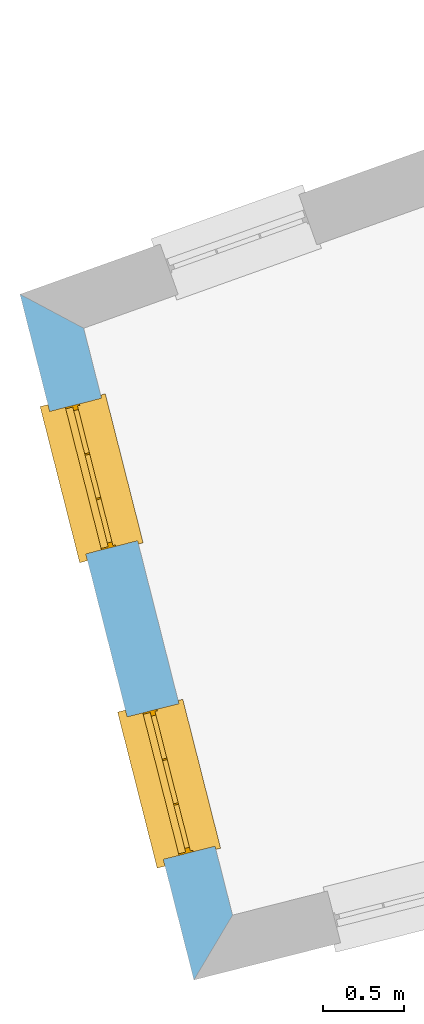
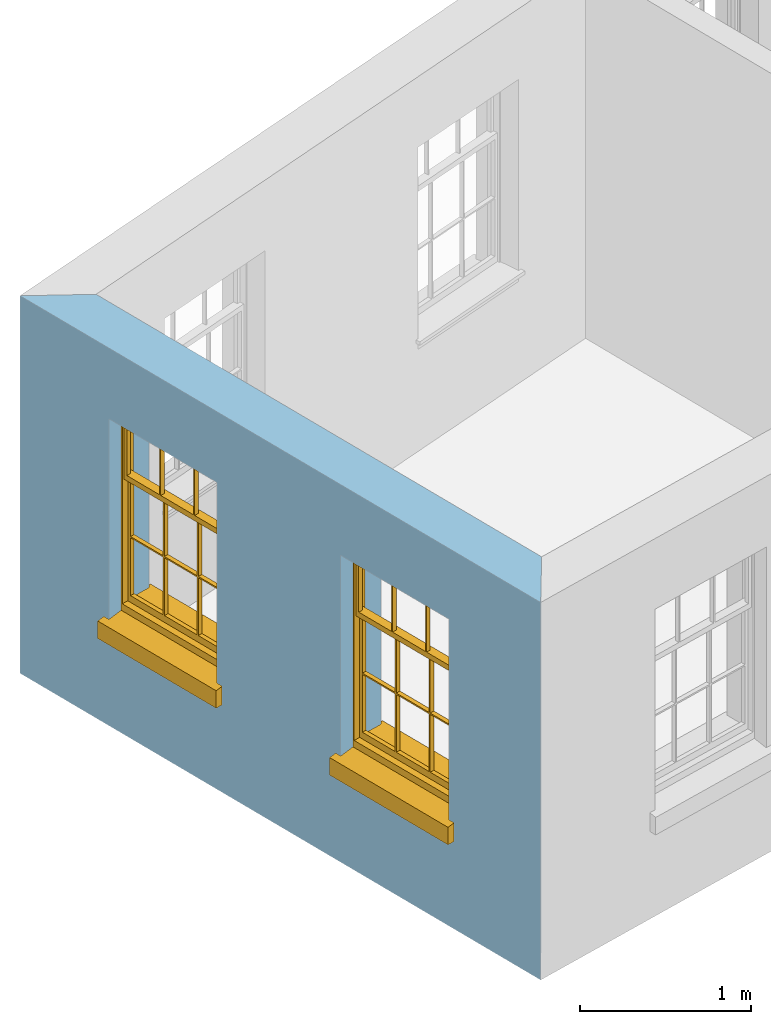
# One storey, part 2 of 10: 2 windows, 2 openings, plus 1 element that does not belong to this part.
"""IFC2X3 building model written with IfcOpenShell, lengths in metres."""

from ifc_helpers import new_model, si_unit, frame, origin, place, context, subcontext, project, spatial, polyline, outline, extrude, faceted_brep, material, layer, layer_set, layer_usage, element, fill, save


model = new_model("IFC2X3")

# Units and contexts
model_context = context("Model", 3, world=origin())
body_context = subcontext(model_context, "Body", "Model", "MODEL_VIEW")
ifc_project = project(units=[si_unit("PLANEANGLEUNIT", "RADIAN"), si_unit("MASSUNIT", "GRAM", prefix="KILO"), si_unit("FORCEUNIT", "NEWTON", prefix="KILO"), si_unit("LENGTHUNIT", "METRE")], contexts=[model_context])

# Site, building, storey
site_placement = place(None, origin())
site = spatial("IfcSite", under=ifc_project, at=site_placement, CompositionType="ELEMENT")
building_placement = place(None, origin())
building = spatial("IfcBuilding", under=site, at=building_placement, Name="Building plot-13", CompositionType="ELEMENT")
storey_placement = place(None, frame((0.0, 0.0, 9.55)))
storey = spatial("IfcBuildingStorey", under=building, at=storey_placement, Name="Floor 2", CompositionType="ELEMENT", Elevation=9.55)

# Wall, openings, windows
ifc_material = material(Name="Masonry")
ifc_layer = layer(ifc_material, 0.33, ventilated=False)
ifc_layer_set = layer_set([ifc_layer], Name="My Wall")
ifc_layer_usage = layer_usage(ifc_layer_set, "AXIS2", "NEGATIVE", 0.08)
wall_placement = place(storey_placement, origin())
wall = element("IfcWallStandardCase", 1, at=wall_placement, inside=storey, material=ifc_layer_usage, Name="exterior", context=body_context, shape_type="SweptSolid", body=[
    extrude(outline(polyline([(65.9065629771408, 47.5401792508866), (65.5129266056267, 47.7498882014907), (66.5879619422004, 43.5112429767636), (66.8267058597151, 43.9122434030099), (65.9065629771408, 47.5401792508866)])), origin(), (0.0, 0.0, 1.0), 2.7),
])
opening_1_placement = place(storey_placement, frame((0.0, 0.0, 0.75)))
opening_1 = element("IfcOpeningElement", 2, at=opening_1_placement, cuts=wall, Name="Opening", ObjectType="Opening", context=body_context, shape_type="SweptSolid", body=[
    extrude(outline(polyline([(65.6963730633974, 47.0265962074796), (65.920090370891, 46.1445244607788), (66.2399625427715, 46.2256527151446), (66.0162452352779, 47.1077244618454), (65.6963730633974, 47.0265962074796)])), origin(), (0.0, 0.0, 1.0), 1.445),
])
opening_2_placement = place(storey_placement, frame((0.0, 0.0, 0.75)))
opening_2 = element("IfcOpeningElement", 3, at=opening_2_placement, cuts=wall, Name="Opening", ObjectType="Opening", context=body_context, shape_type="SweptSolid", body=[
    extrude(outline(polyline([(66.1752193475935, 45.1386029045291), (66.3989366550872, 44.2565311578283), (66.7188088269677, 44.3376594121941), (66.495091519474, 45.2197311588949), (66.1752193475935, 45.1386029045291)])), origin(), (0.0, 0.0, 1.0), 1.445),
])
window_1_placement = place(storey_placement, frame((65.9387004663372, 47.0880570062415, 0.75), z_axis=(0.0, 0.0, 1.0), x_axis=(0.223717307493615, -0.882071746700802, 0.0)))
window_1 = element("IfcWindow", 4, at=window_1_placement, inside=storey, Name="bedroom outside window", OverallHeight=1.445, OverallWidth=0.91, context=body_context, shape_type="Brep", held_by="IfcProductRepresentation", body=[
    faceted_brep([(0.876875, -0.105, 0.999097), (0.876875, -0.105, 1.411875), (0.9, -0.105, 1.435), (0.033125, -0.105, 1.411875), (0.033125, -0.105, 0.999097), (0.01, -0.105, 1.435), (0.033125, -0.135, 1.411875), (0.01, -0.135, 1.435), (0.033125, -0.135, 0.999097), (0.876875, -0.135, 1.411875), (0.876875, -0.135, 0.999097), (0.9, -0.135, 1.435), (0.033125, -0.105, 0.960972), (0.01, -0.105, 0.960972), (0.033125, -0.105, 0.548195), (0.876875, -0.105, 0.960972), (0.876875, -0.105, 0.548195), (0.9, -0.105, 0.960972), (0.876875, -0.105, 0.538195), (0.876875, -0.105, 0.125417), (0.9, -0.105, 0.077167), (0.033125, -0.105, 0.125417), (0.033125, -0.105, 0.538195), (0.01, -0.105, 0.077167), (0.9, -0.135, 0.960972), (0.01, -0.135, 0.960972), (-0.0425, -0.25, 0.01), (-0.0425, -0.3, 0.001667), (0.0, -0.25, 0.01), (0.9525, -0.25, 0.01), (0.91, -0.25, 0.01), (0.9525, -0.3, 0.001667), (-0.02, 0.08, 0.077167), (0.0, 0.08, 0.077167), (-0.02, 0.11, 0.077167), (0.0, -0.06, 0.077167), (0.01, -0.06, 0.077167), (0.91, -0.06, 0.077167), (0.91, 0.08, 0.077167), (0.9, -0.06, 0.077167), (0.93, 0.08, 0.077167), (0.93, 0.11, 0.077167), (0.01, -0.105, 0.999097), (0.01, -0.075, 0.999097), (0.9, -0.105, 0.999097), (0.9, -0.075, 0.999097), (0.876875, -0.075, 0.125417), (0.876875, -0.075, 0.538195), (0.9, -0.075, 0.077167), (0.876875, -0.075, 0.548195), (0.876875, -0.075, 0.960972), (0.033125, -0.075, 0.125417), (0.01, -0.075, 0.077167), (0.033125, -0.075, 0.538195), (0.033125, -0.075, 0.960972), (0.033125, -0.075, 0.548195), (-0.02, 0.08, 0.052167), (-0.02, 0.11, 0.052167), (0.93, 0.11, 0.052167), (0.93, 0.08, 0.052167), (0.91, 0.08, 0.052167), (0.0, 0.08, 0.052167), (0.91, -0.15, 0.026667), (0.0, -0.15, 0.026667), (-0.0425, -0.3, -0.123333), (0.9525, -0.3, -0.123333), (-0.0425, -0.25, -0.123333), (0.9525, -0.25, -0.123333), (0.01, -0.06, 1.435), (0.9, -0.06, 1.435), (0.0, -0.06, 1.445), (0.91, -0.06, 1.445), (0.01, -0.15, 0.077167), (0.9, -0.15, 0.077167), (0.592292, -0.105, 0.125417), (0.592292, -0.075, 0.125417), (0.317708, -0.075, 0.125417), (0.317708, -0.105, 0.125417), (0.592292, -0.105, 0.548195), (0.317708, -0.105, 0.548195), (0.317708, -0.105, 0.538195), (0.592292, -0.105, 0.538195), (0.592292, -0.075, 0.548195), (0.317708, -0.075, 0.548195), (0.602292, -0.075, 0.548195), (0.602292, -0.105, 0.548195), (0.317708, -0.075, 0.538195), (0.307708, -0.075, 0.125417), (0.307708, -0.075, 0.538195), (0.602292, -0.075, 0.538195), (0.602292, -0.075, 0.125417), (0.592292, -0.075, 0.538195), (0.307708, -0.075, 0.548195), (0.317708, -0.075, 0.960972), (0.307708, -0.075, 0.960972), (0.602292, -0.075, 0.960972), (0.592292, -0.075, 0.960972), (0.307708, -0.105, 0.538195), (0.307708, -0.105, 0.125417), (0.307708, -0.105, 0.548195), (0.307708, -0.105, 0.960972), (0.592292, -0.105, 0.960972), (0.317708, -0.105, 0.960972), (0.602292, -0.105, 0.960972), (0.602292, -0.105, 0.538195), (0.602292, -0.105, 0.125417), (0.317708, -0.135, 1.411875), (0.307708, -0.135, 1.411875), (0.307708, -0.135, 0.999097), (0.317708, -0.135, 0.999097), (0.602292, -0.135, 1.411875), (0.592292, -0.135, 1.411875), (0.592292, -0.135, 0.999097), (0.602292, -0.135, 0.999097), (0.317708, -0.105, 0.999097), (0.307708, -0.105, 0.999097), (0.307708, -0.105, 1.411875), (0.317708, -0.105, 1.411875), (0.602292, -0.105, 0.999097), (0.592292, -0.105, 0.999097), (0.592292, -0.105, 1.411875), (0.602292, -0.105, 1.411875), (0.91, -0.15, 1.445), (0.9, -0.15, 1.435), (0.01, -0.15, 1.435), (0.0, -0.15, 1.445), (0.91, -0.25, 0.0), (0.0, -0.25, 0.0), (0.91, 0.08, 0.0), (0.0, 0.08, 0.0)], [[[0, 1, 2]], [[3, 4, 5]], [[6, 7, 8]], [[9, 10, 11]], [[12, 13, 14]], [[15, 16, 17]], [[18, 19, 20]], [[21, 22, 23]], [[24, 15, 17]], [[13, 12, 25]], [[26, 27, 28]], [[29, 30, 31]], [[32, 33, 34]], [[35, 36, 33]], [[37, 38, 39]], [[40, 41, 38]], [[42, 4, 43]], [[44, 45, 0]], [[46, 47, 48]], [[49, 50, 45]], [[51, 52, 53]], [[54, 55, 43]], [[38, 33, 36, 39]], [[41, 34, 33, 38]], [[56, 32, 34, 57]], [[57, 34, 41, 58]], [[58, 41, 40, 59]], [[57, 58, 60, 61]], [[52, 48, 39, 36]], [[62, 63, 28, 30]], [[27, 31, 30, 28]], [[27, 64, 65, 31]], [[66, 67, 65, 64]], [[2, 5, 68, 69]], [[68, 70, 71, 69]], [[20, 23, 72, 73]], [[73, 72, 63, 62]], [[74, 75, 76, 77]], [[78, 79, 80, 81]], [[78, 82, 83, 79]], [[16, 49, 84, 85]], [[86, 76, 87, 88]], [[89, 90, 75, 91]], [[92, 88, 53, 55]], [[82, 91, 86, 83]], [[93, 83, 92, 94]], [[95, 84, 82, 96]], [[89, 84, 49, 47]], [[97, 88, 87, 98]], [[22, 53, 88, 97]], [[81, 91, 75, 74]], [[80, 86, 91, 81]], [[77, 76, 86, 80]], [[99, 92, 55, 14]], [[100, 94, 92, 99]], [[101, 96, 82, 78]], [[79, 83, 93, 102]], [[85, 84, 95, 103]], [[104, 89, 47, 18]], [[105, 90, 89, 104]], [[104, 18, 16, 85]], [[80, 97, 98, 77]], [[104, 81, 74, 105]], [[103, 101, 78, 85]], [[99, 14, 22, 97]], [[102, 100, 99, 79]], [[106, 107, 108, 109]], [[110, 111, 112, 113]], [[114, 115, 116, 117]], [[118, 119, 120, 121]], [[107, 116, 115, 108]], [[111, 120, 119, 112]], [[109, 114, 117, 106]], [[113, 118, 121, 110]], [[85, 78, 81, 104]], [[84, 89, 91, 82]], [[83, 86, 88, 92]], [[79, 99, 97, 80]], [[109, 112, 119, 114]], [[102, 93, 96, 101]], [[106, 117, 120, 111]], [[98, 87, 51, 21]], [[6, 3, 116, 107]], [[110, 121, 1, 9]], [[19, 46, 90, 105]], [[26, 66, 64, 27]], [[29, 31, 65, 67]], [[25, 24, 112, 109]], [[11, 7, 106, 111]], [[75, 48, 52, 76]], [[43, 45, 96, 93]], [[45, 43, 114, 119]], [[5, 2, 120, 117]], [[24, 25, 102, 101]], [[42, 5, 4]], [[2, 44, 0]], [[49, 45, 48, 47]], [[52, 43, 55, 53]], [[14, 13, 23, 22]], [[20, 17, 16, 18]], [[24, 11, 10]], [[25, 8, 7]], [[8, 4, 3, 6]], [[9, 1, 0, 10]], [[15, 50, 49, 16]], [[18, 47, 46, 19]], [[21, 51, 53, 22]], [[14, 55, 54, 12]], [[44, 2, 69, 45]], [[68, 5, 42, 43]], [[36, 35, 70, 68]], [[39, 69, 71, 37]], [[62, 122, 123, 73]], [[63, 72, 124, 125]], [[8, 108, 115, 4]], [[113, 10, 0, 118]], [[94, 100, 12, 54]], [[17, 20, 73, 24]], [[72, 23, 13, 25]], [[52, 36, 68, 43]], [[69, 39, 48, 45]], [[11, 24, 73, 123]], [[7, 124, 72, 25]], [[23, 77, 98]], [[98, 21, 23]], [[105, 74, 20]], [[20, 19, 105]], [[20, 74, 77, 23]], [[113, 112, 24]], [[24, 10, 113]], [[25, 109, 108]], [[108, 8, 25]], [[110, 9, 11]], [[11, 111, 110]], [[7, 6, 107]], [[107, 106, 7]], [[5, 117, 116]], [[116, 3, 5]], [[121, 120, 2]], [[2, 1, 121]], [[11, 123, 124, 7]], [[122, 125, 124, 123]], [[43, 93, 94]], [[94, 54, 43]], [[96, 45, 95]], [[50, 95, 45]], [[15, 103, 95, 50]], [[48, 75, 90]], [[90, 46, 48]], [[87, 76, 52]], [[52, 51, 87]], [[103, 15, 24]], [[24, 101, 103]], [[100, 102, 25]], [[25, 12, 100]], [[115, 114, 43]], [[43, 4, 115]], [[118, 0, 45]], [[45, 119, 118]], [[71, 70, 125, 122]], [[70, 35, 63, 125]], [[122, 62, 37, 71]], [[126, 67, 66, 127]], [[60, 58, 59]], [[38, 60, 59, 40]], [[61, 56, 57]], [[32, 56, 61, 33]], [[61, 60, 128, 129]], [[62, 60, 38, 37]], [[126, 128, 60, 62]], [[33, 61, 63, 35]], [[61, 129, 127, 63]], [[128, 126, 127, 129]], [[28, 127, 66, 26]], [[63, 127, 28]], [[29, 67, 126, 30]], [[30, 126, 62]]]),
])
fill(opening_1, window_1)
window_2_placement = place(storey_placement, frame((66.4175467505333, 45.2000637032911, 0.75), z_axis=(0.0, 0.0, 1.0), x_axis=(0.223717307493615, -0.882071746700802, 0.0)))
window_2 = element("IfcWindow", 5, at=window_2_placement, inside=storey, Name="bedroom outside window", OverallHeight=1.445, OverallWidth=0.91, context=body_context, shape_type="Brep", held_by="IfcProductRepresentation", body=[
    faceted_brep([(0.876875, -0.105, 0.999097), (0.876875, -0.105, 1.411875), (0.9, -0.105, 1.435), (0.033125, -0.105, 1.411875), (0.033125, -0.105, 0.999097), (0.01, -0.105, 1.435), (0.033125, -0.135, 1.411875), (0.01, -0.135, 1.435), (0.033125, -0.135, 0.999097), (0.876875, -0.135, 1.411875), (0.876875, -0.135, 0.999097), (0.9, -0.135, 1.435), (0.033125, -0.105, 0.960972), (0.01, -0.105, 0.960972), (0.033125, -0.105, 0.548195), (0.876875, -0.105, 0.960972), (0.876875, -0.105, 0.548195), (0.9, -0.105, 0.960972), (0.876875, -0.105, 0.538195), (0.876875, -0.105, 0.125417), (0.9, -0.105, 0.077167), (0.033125, -0.105, 0.125417), (0.033125, -0.105, 0.538195), (0.01, -0.105, 0.077167), (0.9, -0.135, 0.960972), (0.01, -0.135, 0.960972), (-0.0425, -0.25, 0.01), (-0.0425, -0.3, 0.001667), (0.0, -0.25, 0.01), (0.9525, -0.25, 0.01), (0.91, -0.25, 0.01), (0.9525, -0.3, 0.001667), (-0.02, 0.08, 0.077167), (0.0, 0.08, 0.077167), (-0.02, 0.11, 0.077167), (0.0, -0.06, 0.077167), (0.01, -0.06, 0.077167), (0.91, -0.06, 0.077167), (0.91, 0.08, 0.077167), (0.9, -0.06, 0.077167), (0.93, 0.08, 0.077167), (0.93, 0.11, 0.077167), (0.01, -0.105, 0.999097), (0.01, -0.075, 0.999097), (0.9, -0.105, 0.999097), (0.9, -0.075, 0.999097), (0.876875, -0.075, 0.125417), (0.876875, -0.075, 0.538195), (0.9, -0.075, 0.077167), (0.876875, -0.075, 0.548195), (0.876875, -0.075, 0.960972), (0.033125, -0.075, 0.125417), (0.01, -0.075, 0.077167), (0.033125, -0.075, 0.538195), (0.033125, -0.075, 0.960972), (0.033125, -0.075, 0.548195), (-0.02, 0.08, 0.052167), (-0.02, 0.11, 0.052167), (0.93, 0.11, 0.052167), (0.93, 0.08, 0.052167), (0.91, 0.08, 0.052167), (0.0, 0.08, 0.052167), (0.91, -0.15, 0.026667), (0.0, -0.15, 0.026667), (-0.0425, -0.3, -0.123333), (0.9525, -0.3, -0.123333), (-0.0425, -0.25, -0.123333), (0.9525, -0.25, -0.123333), (0.01, -0.06, 1.435), (0.9, -0.06, 1.435), (0.0, -0.06, 1.445), (0.91, -0.06, 1.445), (0.01, -0.15, 0.077167), (0.9, -0.15, 0.077167), (0.592292, -0.105, 0.125417), (0.592292, -0.075, 0.125417), (0.317708, -0.075, 0.125417), (0.317708, -0.105, 0.125417), (0.592292, -0.105, 0.548195), (0.317708, -0.105, 0.548195), (0.317708, -0.105, 0.538195), (0.592292, -0.105, 0.538195), (0.592292, -0.075, 0.548195), (0.317708, -0.075, 0.548195), (0.602292, -0.075, 0.548195), (0.602292, -0.105, 0.548195), (0.317708, -0.075, 0.538195), (0.307708, -0.075, 0.125417), (0.307708, -0.075, 0.538195), (0.602292, -0.075, 0.538195), (0.602292, -0.075, 0.125417), (0.592292, -0.075, 0.538195), (0.307708, -0.075, 0.548195), (0.317708, -0.075, 0.960972), (0.307708, -0.075, 0.960972), (0.602292, -0.075, 0.960972), (0.592292, -0.075, 0.960972), (0.307708, -0.105, 0.538195), (0.307708, -0.105, 0.125417), (0.307708, -0.105, 0.548195), (0.307708, -0.105, 0.960972), (0.592292, -0.105, 0.960972), (0.317708, -0.105, 0.960972), (0.602292, -0.105, 0.960972), (0.602292, -0.105, 0.538195), (0.602292, -0.105, 0.125417), (0.317708, -0.135, 1.411875), (0.307708, -0.135, 1.411875), (0.307708, -0.135, 0.999097), (0.317708, -0.135, 0.999097), (0.602292, -0.135, 1.411875), (0.592292, -0.135, 1.411875), (0.592292, -0.135, 0.999097), (0.602292, -0.135, 0.999097), (0.317708, -0.105, 0.999097), (0.307708, -0.105, 0.999097), (0.307708, -0.105, 1.411875), (0.317708, -0.105, 1.411875), (0.602292, -0.105, 0.999097), (0.592292, -0.105, 0.999097), (0.592292, -0.105, 1.411875), (0.602292, -0.105, 1.411875), (0.91, -0.15, 1.445), (0.9, -0.15, 1.435), (0.01, -0.15, 1.435), (0.0, -0.15, 1.445), (0.91, -0.25, 0.0), (0.0, -0.25, 0.0), (0.91, 0.08, 0.0), (0.0, 0.08, 0.0)], [[[0, 1, 2]], [[3, 4, 5]], [[6, 7, 8]], [[9, 10, 11]], [[12, 13, 14]], [[15, 16, 17]], [[18, 19, 20]], [[21, 22, 23]], [[24, 15, 17]], [[13, 12, 25]], [[26, 27, 28]], [[29, 30, 31]], [[32, 33, 34]], [[35, 36, 33]], [[37, 38, 39]], [[40, 41, 38]], [[42, 4, 43]], [[44, 45, 0]], [[46, 47, 48]], [[49, 50, 45]], [[51, 52, 53]], [[54, 55, 43]], [[38, 33, 36, 39]], [[41, 34, 33, 38]], [[56, 32, 34, 57]], [[57, 34, 41, 58]], [[58, 41, 40, 59]], [[57, 58, 60, 61]], [[52, 48, 39, 36]], [[62, 63, 28, 30]], [[27, 31, 30, 28]], [[27, 64, 65, 31]], [[66, 67, 65, 64]], [[2, 5, 68, 69]], [[68, 70, 71, 69]], [[20, 23, 72, 73]], [[73, 72, 63, 62]], [[74, 75, 76, 77]], [[78, 79, 80, 81]], [[78, 82, 83, 79]], [[16, 49, 84, 85]], [[86, 76, 87, 88]], [[89, 90, 75, 91]], [[92, 88, 53, 55]], [[82, 91, 86, 83]], [[93, 83, 92, 94]], [[95, 84, 82, 96]], [[89, 84, 49, 47]], [[97, 88, 87, 98]], [[22, 53, 88, 97]], [[81, 91, 75, 74]], [[80, 86, 91, 81]], [[77, 76, 86, 80]], [[99, 92, 55, 14]], [[100, 94, 92, 99]], [[101, 96, 82, 78]], [[79, 83, 93, 102]], [[85, 84, 95, 103]], [[104, 89, 47, 18]], [[105, 90, 89, 104]], [[104, 18, 16, 85]], [[80, 97, 98, 77]], [[104, 81, 74, 105]], [[103, 101, 78, 85]], [[99, 14, 22, 97]], [[102, 100, 99, 79]], [[106, 107, 108, 109]], [[110, 111, 112, 113]], [[114, 115, 116, 117]], [[118, 119, 120, 121]], [[107, 116, 115, 108]], [[111, 120, 119, 112]], [[109, 114, 117, 106]], [[113, 118, 121, 110]], [[85, 78, 81, 104]], [[84, 89, 91, 82]], [[83, 86, 88, 92]], [[79, 99, 97, 80]], [[109, 112, 119, 114]], [[102, 93, 96, 101]], [[106, 117, 120, 111]], [[98, 87, 51, 21]], [[6, 3, 116, 107]], [[110, 121, 1, 9]], [[19, 46, 90, 105]], [[26, 66, 64, 27]], [[29, 31, 65, 67]], [[25, 24, 112, 109]], [[11, 7, 106, 111]], [[75, 48, 52, 76]], [[43, 45, 96, 93]], [[45, 43, 114, 119]], [[5, 2, 120, 117]], [[24, 25, 102, 101]], [[42, 5, 4]], [[2, 44, 0]], [[49, 45, 48, 47]], [[52, 43, 55, 53]], [[14, 13, 23, 22]], [[20, 17, 16, 18]], [[24, 11, 10]], [[25, 8, 7]], [[8, 4, 3, 6]], [[9, 1, 0, 10]], [[15, 50, 49, 16]], [[18, 47, 46, 19]], [[21, 51, 53, 22]], [[14, 55, 54, 12]], [[44, 2, 69, 45]], [[68, 5, 42, 43]], [[36, 35, 70, 68]], [[39, 69, 71, 37]], [[62, 122, 123, 73]], [[63, 72, 124, 125]], [[8, 108, 115, 4]], [[113, 10, 0, 118]], [[94, 100, 12, 54]], [[17, 20, 73, 24]], [[72, 23, 13, 25]], [[52, 36, 68, 43]], [[69, 39, 48, 45]], [[11, 24, 73, 123]], [[7, 124, 72, 25]], [[23, 77, 98]], [[98, 21, 23]], [[105, 74, 20]], [[20, 19, 105]], [[20, 74, 77, 23]], [[113, 112, 24]], [[24, 10, 113]], [[25, 109, 108]], [[108, 8, 25]], [[110, 9, 11]], [[11, 111, 110]], [[7, 6, 107]], [[107, 106, 7]], [[5, 117, 116]], [[116, 3, 5]], [[121, 120, 2]], [[2, 1, 121]], [[11, 123, 124, 7]], [[122, 125, 124, 123]], [[43, 93, 94]], [[94, 54, 43]], [[96, 45, 95]], [[50, 95, 45]], [[15, 103, 95, 50]], [[48, 75, 90]], [[90, 46, 48]], [[87, 76, 52]], [[52, 51, 87]], [[103, 15, 24]], [[24, 101, 103]], [[100, 102, 25]], [[25, 12, 100]], [[115, 114, 43]], [[43, 4, 115]], [[118, 0, 45]], [[45, 119, 118]], [[71, 70, 125, 122]], [[70, 35, 63, 125]], [[122, 62, 37, 71]], [[126, 67, 66, 127]], [[60, 58, 59]], [[38, 60, 59, 40]], [[61, 56, 57]], [[32, 56, 61, 33]], [[61, 60, 128, 129]], [[62, 60, 38, 37]], [[126, 128, 60, 62]], [[33, 61, 63, 35]], [[61, 129, 127, 63]], [[128, 126, 127, 129]], [[28, 127, 66, 26]], [[63, 127, 28]], [[29, 67, 126, 30]], [[30, 126, 62]]]),
])
fill(opening_2, window_2)

save(model, "model.ifc")
